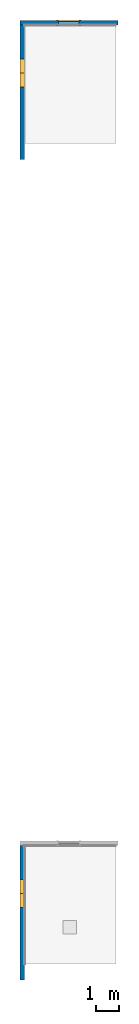
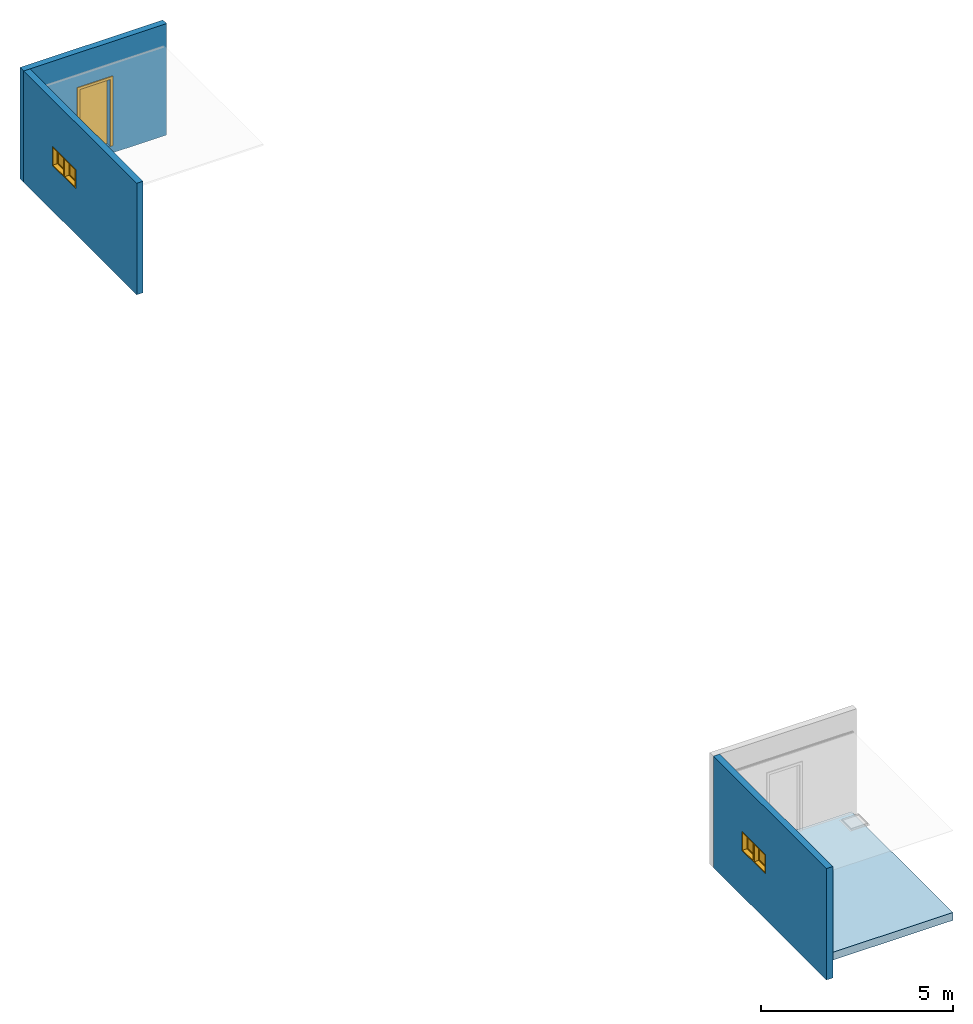
# One storey, part 1 of 5: 4 windows, 3 walls, 1 door, 1 slab, 5 openings.
"""IFC2X3 building model written with IfcOpenShell, lengths in millimetres."""

from ifc_helpers import new_model, entity, si_unit, converted_unit, derived_unit, direction, frame, frame_2d, origin, origin_2d_with_axis, place, context, subcontext, project, spatial, polyline, rectangle, outline, extrude, source, transform, mapped, material, material_list, layer, layer_set, layer_usage, type_object, type_shapes, element, fill, save


model = new_model("IFC2X3")

# Units and contexts
model_context = context("Model", 3, precision=0.01, world=origin(), true_north=direction((6.12303176911189e-17, 1.0)))
body_context = subcontext(model_context, "Body", "Model", "MODEL_VIEW")
ifc_project = project(units=[si_unit("LENGTHUNIT", "METRE", prefix="MILLI"), si_unit("AREAUNIT", "SQUARE_METRE"), si_unit("VOLUMEUNIT", "CUBIC_METRE"), converted_unit("PLANEANGLEUNIT", "DEGREE", entity("IfcRatioMeasure", 0.0174532925199433), si_unit("PLANEANGLEUNIT", "RADIAN"), dimensions=[0, 0, 0, 0, 0, 0, 0]), si_unit("MASSUNIT", "GRAM", prefix="KILO"), derived_unit("MASSDENSITYUNIT", [(si_unit("MASSUNIT", "GRAM", prefix="KILO"), 1), (si_unit("LENGTHUNIT", "METRE"), -3)]), si_unit("TIMEUNIT", "SECOND"), si_unit("FREQUENCYUNIT", "HERTZ"), si_unit("THERMODYNAMICTEMPERATUREUNIT", "DEGREE_CELSIUS"), derived_unit("THERMALTRANSMITTANCEUNIT", [(si_unit("MASSUNIT", "GRAM", prefix="KILO"), 1), (si_unit("THERMODYNAMICTEMPERATUREUNIT", "KELVIN"), -1), (si_unit("TIMEUNIT", "SECOND"), -3)]), derived_unit("VOLUMETRICFLOWRATEUNIT", [(si_unit("LENGTHUNIT", "METRE"), 3), (si_unit("TIMEUNIT", "SECOND"), -1)]), si_unit("ELECTRICCURRENTUNIT", "AMPERE"), si_unit("ELECTRICVOLTAGEUNIT", "VOLT"), si_unit("POWERUNIT", "WATT"), si_unit("FORCEUNIT", "NEWTON", prefix="KILO"), si_unit("ILLUMINANCEUNIT", "LUX"), si_unit("LUMINOUSFLUXUNIT", "LUMEN"), si_unit("LUMINOUSINTENSITYUNIT", "CANDELA"), derived_unit("USERDEFINED", [(si_unit("MASSUNIT", "GRAM", prefix="KILO"), -1), (si_unit("LENGTHUNIT", "METRE"), -2), (si_unit("TIMEUNIT", "SECOND"), 3), (si_unit("LUMINOUSFLUXUNIT", "LUMEN"), 1)]), derived_unit("LINEARVELOCITYUNIT", [(si_unit("LENGTHUNIT", "METRE"), 1), (si_unit("TIMEUNIT", "SECOND"), -1)]), si_unit("PRESSUREUNIT", "PASCAL"), derived_unit("USERDEFINED", [(si_unit("LENGTHUNIT", "METRE"), -2), (si_unit("MASSUNIT", "GRAM", prefix="KILO"), 1), (si_unit("TIMEUNIT", "SECOND"), -2)])], contexts=[model_context])

# Site, building, storey
site_placement = place(None, origin())
site = spatial("IfcSite", under=ifc_project, at=site_placement, CompositionType="ELEMENT")
building_placement = place(site_placement, origin())
building = spatial("IfcBuilding", under=site, at=building_placement, CompositionType="ELEMENT")
storey_placement = place(building_placement, origin())
storey = spatial("IfcBuildingStorey", under=building, at=storey_placement, Name="Base Level", CompositionType="ELEMENT", Elevation=0.0)

# Slab
ifc_material_1 = material(Name="_Generic Model White")
ifc_layer_1 = layer(ifc_material_1, 250.0)
ifc_layer_set_1 = layer_set([ifc_layer_1], Name="Floor:Generic Floor - 250mm")
ifc_layer_usage_1 = layer_usage(ifc_layer_set_1, "AXIS3", "POSITIVE", 0.0)
slab_type = type_object("IfcSlabType", Name="Floor:Generic Floor - 250mm", PredefinedType="FLOOR", material=ifc_layer_set_1)
slab_placement = place(building_placement, origin())
element("IfcSlab", 1, at=slab_placement, inside=storey, type_object=slab_type, material=ifc_layer_usage_1, Name="Floor:Generic Floor - 250mm:2491", ObjectType="Floor:Generic Floor - 250mm", PredefinedType="FLOOR", context=body_context, shape_type="SweptSolid", body=[
    extrude(rectangle(XDim=5300.0, YDim=4100.0, at=origin_2d_with_axis()), frame((107416.734552934, 3662.91938039375, 0.0), z_axis=(0.0, 0.0, -1.0), x_axis=(0.0, 1.0, 0.0)), (0.0, 0.0, 1.0), 250.0),
])

# Wall, openings, windows
ifc_material_2 = material(Name="np_Plastered")
ifc_layer_2 = layer(ifc_material_2, 190.0)
ifc_layer_set_2 = layer_set([ifc_layer_2], Name="Basic Wall:190mm BLOCK- plastered")
ifc_layer_usage_2 = layer_usage(ifc_layer_set_2, "AXIS2", "NEGATIVE", 95.0)
wall_type = type_object("IfcWallType", Name="Basic Wall:190mm BLOCK- plastered", PredefinedType="STANDARD", material=ifc_layer_set_2)
wall_1_placement = place(building_placement, frame((105347.734552934, 312.919380393758, -250.0), z_axis=(0.0, 0.0, 1.0), x_axis=(0.0, 1.0, 0.0)))
wall_1 = element("IfcWallStandardCase", 2, at=wall_1_placement, inside=storey, type_object=wall_type, material=ifc_layer_usage_2, Name="Basic Wall:190mm BLOCK- plastered:2497", ObjectType="Basic Wall:190mm BLOCK- plastered", context=body_context, shape_type="SweptSolid", body=[
    extrude(rectangle(XDim=5905.0, YDim=189.999999999991, at=frame_2d((2952.5, 4.2703618419182e-12), x_axis=(-1.0, 0.0))), origin(), (0.0, 0.0, 1.0), 3550.00000000014),
])
opening_1_placement = place(wall_1_placement, frame((4405.0, 95.0, 1450.0)))
opening_1 = element("IfcOpeningElement", 3, at=opening_1_placement, cuts=wall_1, Name="M_Fixed:0610 x 0610mm:2514:1", ObjectType="Opening", context=body_context, shape_type="SweptSolid", body=[
    extrude(rectangle(XDim=609.999999999999, YDim=609.999999999999, at=frame_2d((304.999999999999, 305.0), x_axis=(1.0, 0.0))), frame((0.0, 0.0, 0.0), z_axis=(0.0, -1.0, 0.0), x_axis=(0.0, 0.0, 1.0)), (0.0, 0.0, 1.0), 190.0),
])
opening_2_placement = place(wall_1_placement, frame((3795.0, 95.0, 1450.0)))
opening_2 = element("IfcOpeningElement", 4, at=opening_2_placement, cuts=wall_1, Name="M_Fixed:0610 x 0610mm:2515:1", ObjectType="Opening", context=body_context, shape_type="SweptSolid", body=[
    extrude(rectangle(XDim=609.999999999999, YDim=609.999999999999, at=frame_2d((304.999999999999, 305.0), x_axis=(1.0, 0.0))), frame((0.0, 0.0, 0.0), z_axis=(0.0, -1.0, 0.0), x_axis=(0.0, 0.0, 1.0)), (0.0, 0.0, 1.0), 190.0),
])
ifc_material_3 = material(Name="Glass")
ifc_material_4 = material(Name="Sash")
ifc_material_list_1 = material_list([ifc_material_3, ifc_material_4])
ifc_material_list_2 = material_list([ifc_material_3, ifc_material_4])
window_style = type_object("IfcWindowStyle", Name="0610 x 0610mm", ConstructionType="NOTDEFINED", OperationType="NOTDEFINED", ParameterTakesPrecedence=False, Sizeable=False, material=ifc_material_list_2)
shared_shape_1 = source(origin(), body_context, "Body", "SweptSolid", [
    extrude(rectangle(XDim=12.0, YDim=483.999999999998, at=frame_2d((8.43769498715119e-15, 0.0), x_axis=(1.0, 0.0))), frame((305.0, 149.0, 63.0), z_axis=(0.0, 0.0, 1.0), x_axis=(0.0, -1.0, 0.0)), (0.0, 0.0, 1.0), 484.000000000008),
    extrude(outline(polyline([(-286.0, -286.0), (286.0, -286.0), (286.0, 286.0), (-286.0, 286.0), (-286.0, -286.0)]), holes=[polyline([(-242.0, -242.0), (-242.0, 242.0), (242.0, 242.0), (242.0, -242.0), (-242.0, -242.0)])]), frame((305.0, 127.0, 305.0), z_axis=(0.0, 1.0, 0.0), x_axis=(1.0, 0.0, 0.0)), (0.0, 0.0, 1.0), 44.0000000000274),
    extrude(outline(polyline([(-305.0, -305.0), (305.0, -305.0), (305.0, 305.0), (-305.0, 305.0), (-305.0, -305.0)]), holes=[polyline([(-286.0, -286.0), (-286.0, 286.0), (286.0, 286.0), (286.0, -286.0), (-286.0, -286.0)])]), frame((305.0, 127.0, 305.0), z_axis=(0.0, 1.0, 0.0), x_axis=(1.0, 0.0, 0.0)), (0.0, 0.0, 1.0), 63.0000000000274),
    extrude(outline(polyline([(-305.0, -305.0), (305.0, -305.0), (305.0, 305.0), (-305.0, 305.0), (-305.0, -305.0)]), holes=[polyline([(-273.0, -273.0), (-273.0, 273.0), (273.0, 273.0), (273.0, -273.0), (-273.0, -273.0)])]), frame((305.0, 0.0, 305.0), z_axis=(0.0, 1.0, 0.0), x_axis=(1.0, 0.0, 0.0)), (0.0, 0.0, 1.0), 126.999999999973),
])
type_shapes(window_style, [shared_shape_1])
window_1_placement = place(opening_1_placement, frame((0.0, 0.0, 0.0), z_axis=(0.0, 0.0, 1.0), x_axis=(-1.0, 0.0, 0.0)))
window_1 = element("IfcWindow", 5, at=window_1_placement, inside=storey, type_object=window_style, material=ifc_material_list_1, Name="M_Fixed:0610 x 0610mm:2514", ObjectType="M_Fixed:0610 x 0610mm", OverallHeight=609.999999999999, OverallWidth=609.999999999999, context=body_context, shape_type="MappedRepresentation", body=[
    mapped(shared_shape_1, transform((0.0, 0.0, 0.0), scale=1.0)),
])
fill(opening_1, window_1)
ifc_material_list_3 = material_list([ifc_material_3, ifc_material_4])
window_2_placement = place(opening_2_placement, frame((0.0, 0.0, 0.0), z_axis=(0.0, 0.0, 1.0), x_axis=(-1.0, 0.0, 0.0)))
window_2 = element("IfcWindow", 6, at=window_2_placement, inside=storey, type_object=window_style, material=ifc_material_list_3, Name="M_Fixed:0610 x 0610mm:2515", ObjectType="M_Fixed:0610 x 0610mm", OverallHeight=609.999999999999, OverallWidth=609.999999999999, context=body_context, shape_type="MappedRepresentation", body=[
    mapped(shared_shape_1, transform((0.0, 0.0, 0.0), scale=1.0)),
])
fill(opening_2, window_2)

# Wall, opening, door
ifc_layer_usage_3 = layer_usage(ifc_layer_set_2, "AXIS2", "NEGATIVE", 95.0)
wall_2_placement = place(building_placement, frame((105252.734552934, 42312.9193803938, -250.0)))
wall_2 = element("IfcWallStandardCase", 7, at=wall_2_placement, inside=storey, type_object=wall_type, material=ifc_layer_usage_3, Name="Basic Wall:190mm BLOCK- plastered:2523", ObjectType="Basic Wall:190mm BLOCK- plastered", context=body_context, shape_type="SweptSolid", body=[
    extrude(rectangle(XDim=4309.00000000003, YDim=189.999999999991, at=frame_2d((2154.50000000001, 2.8208546609676e-12), x_axis=(-1.0, 0.0))), origin(), (0.0, 0.0, 1.0), 3550.00000000014),
])
opening_3_placement = place(wall_2_placement, frame((1684.50000000011, -95.0, 250.0)))
opening_3 = element("IfcOpeningElement", 8, at=opening_3_placement, cuts=wall_2, Name="M_Single-Flush:0915 x 2134mm:2524:1", ObjectType="Opening", context=body_context, shape_type="SweptSolid", body=[
    extrude(rectangle(XDim=915.0, YDim=2134.0, at=frame_2d((1067.0, 457.5), x_axis=(0.0, 1.0))), frame((0.0, 0.0, 0.0), z_axis=(0.0, 1.0, 0.0), x_axis=(0.0, 0.0, 1.0)), (0.0, 0.0, 1.0), 190.0),
])
ifc_material_5 = material(Name="Door - Frame")
ifc_material_6 = material(Name="Door - Panel")
ifc_material_list_4 = material_list([ifc_material_5, ifc_material_6])
ifc_material_list_5 = material_list([ifc_material_5, ifc_material_6])
door_style = type_object("IfcDoorStyle", Name="0915 x 2134mm", ConstructionType="NOTDEFINED", OperationType="SINGLE_SWING_RIGHT", ParameterTakesPrecedence=False, Sizeable=False, material=ifc_material_list_5)
shared_shape_2 = source(origin(), body_context, "Body", "SweptSolid", [
    extrude(outline(polyline([(-533.5, -1124.0), (533.5, -1124.0), (533.5, 1086.0), (457.5, 1086.0), (457.5, -1048.0), (-457.5, -1048.0), (-457.5, 1086.0), (-533.5, 1086.0), (-533.5, -1124.0)])), frame((457.500000000001, 190.0, 1086.0), z_axis=(0.0, 1.0, 0.0), x_axis=(1.0, 0.0, 0.0)), (0.0, 0.0, 1.0), 24.9999999999945),
    extrude(outline(polyline([(-1124.0, -533.499999999997), (1086.0, -533.499999999997), (1086.0, -457.500000000007), (-1048.0, -457.500000000007), (-1048.0, 457.500000000002), (1086.0, 457.500000000002), (1086.0, 533.500000000003), (-1124.0, 533.500000000003), (-1124.0, -533.499999999997)])), frame((457.500000000003, -25.0, 1086.0), z_axis=(0.0, 1.0, 0.0), x_axis=(0.0, 0.0, -1.0)), (0.0, 0.0, 1.0), 25.0000000000056),
    extrude(rectangle(XDim=51.0, YDim=915.0, at=frame_2d((5.32907051820075e-15, 0.0), x_axis=(1.0, 0.0))), frame((457.5, 164.499999999999, 0.0), z_axis=(0.0, 0.0, 1.0), x_axis=(0.0, 1.0, 0.0)), (0.0, 0.0, 1.0), 2134.0),
])
type_shapes(door_style, [shared_shape_2])
door_placement = place(opening_3_placement, origin())
door = element("IfcDoor", 9, at=door_placement, inside=storey, type_object=door_style, material=ifc_material_list_4, Name="M_Single-Flush:0915 x 2134mm:2524", ObjectType="M_Single-Flush:0915 x 2134mm", OverallHeight=2134.0, OverallWidth=915.0, context=body_context, shape_type="MappedRepresentation", body=[
    mapped(shared_shape_2, transform((0.0, 0.0, 0.0), scale=1.0)),
])
fill(opening_3, door)

# Wall, openings, windows
ifc_layer_usage_4 = layer_usage(ifc_layer_set_2, "AXIS2", "NEGATIVE", 95.0)
wall_3_placement = place(building_placement, frame((105347.734552934, 36312.9193803938, -250.0), z_axis=(0.0, 0.0, 1.0), x_axis=(0.0, 1.0, 0.0)))
wall_3 = element("IfcWallStandardCase", 10, at=wall_3_placement, inside=storey, type_object=wall_type, material=ifc_layer_usage_4, Name="Basic Wall:190mm BLOCK- plastered:2525", ObjectType="Basic Wall:190mm BLOCK- plastered", context=body_context, shape_type="SweptSolid", body=[
    extrude(rectangle(XDim=5905.0, YDim=189.999999999991, at=frame_2d((2952.5, 4.2703618419182e-12), x_axis=(-1.0, 0.0))), origin(), (0.0, 0.0, 1.0), 3550.00000000014),
])
opening_4_placement = place(wall_3_placement, frame((4405.0, 95.0, 1450.0)))
opening_4 = element("IfcOpeningElement", 11, at=opening_4_placement, cuts=wall_3, Name="M_Fixed:0610 x 0610mm:2528:1", ObjectType="Opening", context=body_context, shape_type="SweptSolid", body=[
    extrude(rectangle(XDim=609.999999999999, YDim=609.999999999999, at=frame_2d((304.999999999999, 305.0), x_axis=(1.0, 0.0))), frame((0.0, 0.0, 0.0), z_axis=(0.0, -1.0, 0.0), x_axis=(0.0, 0.0, 1.0)), (0.0, 0.0, 1.0), 190.0),
])
opening_5_placement = place(wall_3_placement, frame((3795.0, 95.0, 1450.0)))
opening_5 = element("IfcOpeningElement", 12, at=opening_5_placement, cuts=wall_3, Name="M_Fixed:0610 x 0610mm:2529:1", ObjectType="Opening", context=body_context, shape_type="SweptSolid", body=[
    extrude(rectangle(XDim=609.999999999999, YDim=609.999999999999, at=frame_2d((304.999999999999, 305.0), x_axis=(1.0, 0.0))), frame((0.0, 0.0, 0.0), z_axis=(0.0, -1.0, 0.0), x_axis=(0.0, 0.0, 1.0)), (0.0, 0.0, 1.0), 190.0),
])
ifc_material_list_6 = material_list([ifc_material_3, ifc_material_4])
window_3_placement = place(opening_4_placement, frame((0.0, 0.0, 0.0), z_axis=(0.0, 0.0, 1.0), x_axis=(-1.0, 0.0, 0.0)))
window_3 = element("IfcWindow", 13, at=window_3_placement, inside=storey, type_object=window_style, material=ifc_material_list_6, Name="M_Fixed:0610 x 0610mm:2528", ObjectType="M_Fixed:0610 x 0610mm", OverallHeight=609.999999999999, OverallWidth=610.0, context=body_context, shape_type="MappedRepresentation", body=[
    mapped(shared_shape_1, transform((0.0, 0.0, 0.0), scale=1.0)),
])
fill(opening_4, window_3)
ifc_material_list_7 = material_list([ifc_material_3, ifc_material_4])
window_4_placement = place(opening_5_placement, frame((0.0, 0.0, 0.0), z_axis=(0.0, 0.0, 1.0), x_axis=(-1.0, 0.0, 0.0)))
window_4 = element("IfcWindow", 14, at=window_4_placement, inside=storey, type_object=window_style, material=ifc_material_list_7, Name="M_Fixed:0610 x 0610mm:2529", ObjectType="M_Fixed:0610 x 0610mm", OverallHeight=609.999999999999, OverallWidth=610.0, context=body_context, shape_type="MappedRepresentation", body=[
    mapped(shared_shape_1, transform((0.0, 0.0, 0.0), scale=1.0)),
])
fill(opening_5, window_4)

save(model, "model.ifc")
